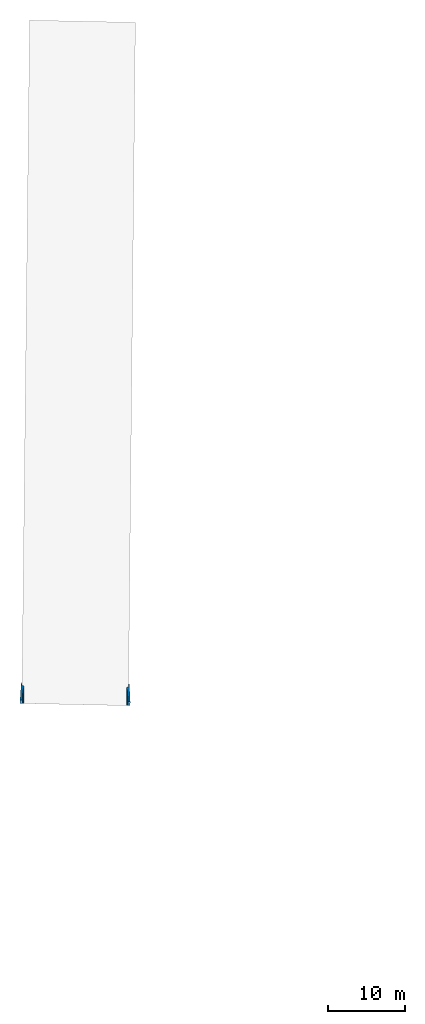
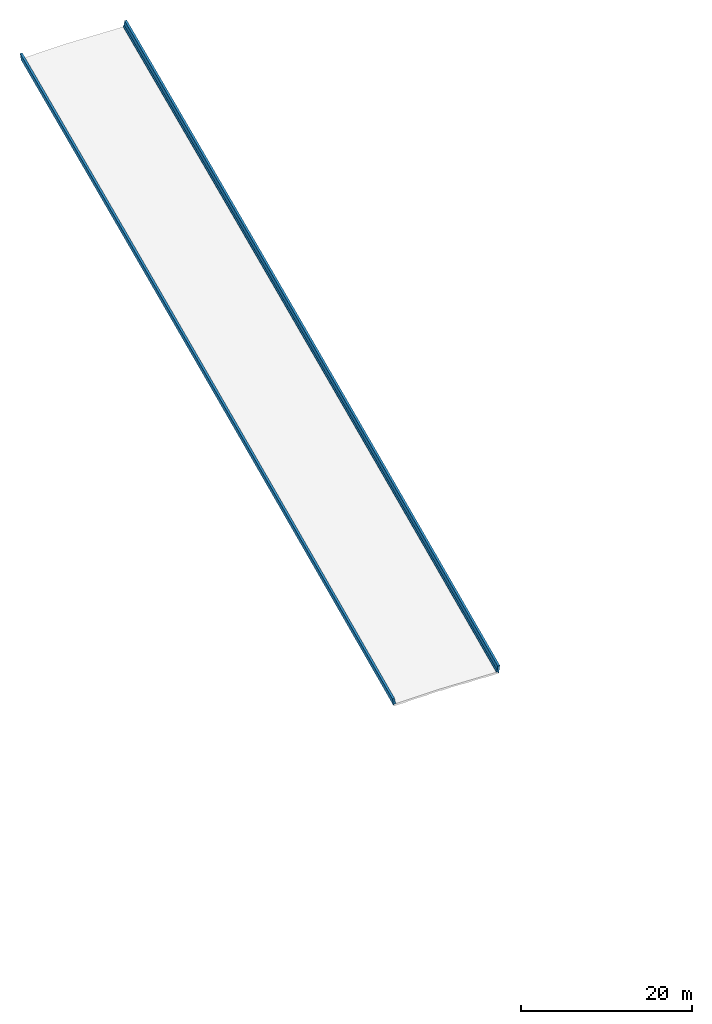
# Not in any storey, part 7 of 7: 2 walls.
"""IFC4X3_ADD2 model written with IfcOpenShell, lengths in metres."""

from ifc_helpers import new_model, entity, si_unit, direction, origin_with_axes, place, context, subcontext, project, spatial, element, save


model = new_model("IFC4X3_ADD2")

# Units and contexts
model_context = context("Model", 3, precision=1e-05, world=origin_with_axes(), true_north=direction((0.0, 1.0)))
body_context = subcontext(model_context, "Body", "Model", "MODEL_VIEW")
ifc_project = project(units=[si_unit("LENGTHUNIT", "METRE"), si_unit("PLANEANGLEUNIT", "RADIAN")], contexts=[model_context])

# Site, bridge, bridge part
placement = place(None, origin_with_axes())
site = spatial("IfcSite", under=ifc_project, at=placement, CompositionType="ELEMENT")
bridge = spatial("IfcBridge", under=site, CompositionType="COMPLEX", PredefinedType="GIRDER")
bridge_part = spatial("IfcBridgePart", under=bridge, CompositionType="PARTIAL", PredefinedType="SUPERSTRUCTURE", UsageType="LONGITUDINAL")

# Walls
gradient_curve_1 = entity("IfcGradientCurve", [entity("IfcCurveSegment", "CONTSAMEGRADIENT", entity("IfcAxis2Placement2D", entity("IfcCartesianPoint", [0.0, 225.3996]), entity("IfcDirection", [0.999837986875874, 0.018])), entity("IfcLengthMeasure", 0.0), entity("IfcLengthMeasure", 152.4), entity("IfcPolynomialCurve", entity("IfcAxis2Placement2D", entity("IfcCartesianPoint", [0.0, 0.0]), entity("IfcDirection", [1.0, 0.0])), [0.0, 1.0], [225.3996, 0.018, -0.000142388451443569])), entity("IfcCurveSegment", "CONTSAMEGRADIENT", entity("IfcAxis2Placement2D", entity("IfcCartesianPoint", [152.4, 224.83572]), entity("IfcDirection", [0.999677367954282, -0.0253999999999999])), entity("IfcLengthMeasure", 0.0), entity("IfcLengthMeasure", 19.2237360000008), entity("IfcLine", entity("IfcCartesianPoint", [0.0, 0.0]), entity("IfcVector", entity("IfcDirection", [1.0, 0.0]), 1.0))), entity("IfcCurveSegment", "DISCONTINUOUS", entity("IfcAxis2Placement2D", entity("IfcCartesianPoint", [152.4, 224.83572]), entity("IfcDirection", [0.999677367954282, -0.0253999999999999])), entity("IfcLengthMeasure", 0.0), entity("IfcLengthMeasure", 0.0), entity("IfcLine", entity("IfcCartesianPoint", [0.0, 0.0]), entity("IfcVector", entity("IfcDirection", [1.0, 0.0]), 1.0)))], False, entity("IfcCompositeCurve", [entity("IfcCurveSegment", "CONTSAMEGRADIENT", entity("IfcAxis2Placement2D", entity("IfcCartesianPoint", [80.2547679528969, 3851.83601829113]), entity("IfcDirection", [0.0208309370620953, 0.999783012488767])), entity("IfcLengthMeasure", 0.0), entity("IfcLengthMeasure", 171.623736), entity("IfcLine", entity("IfcCartesianPoint", [0.0, 0.0]), entity("IfcVector", entity("IfcDirection", [1.0, 0.0]), 1.0))), entity("IfcCurveSegment", "DISCONTINUOUS", entity("IfcAxis2Placement2D", entity("IfcCartesianPoint", [83.8298511958746, 4023.42251408378]), entity("IfcDirection", [0.0208309370620953, 0.999783012488767])), entity("IfcLengthMeasure", 0.0), entity("IfcLengthMeasure", 0.0), entity("IfcLine", entity("IfcCartesianPoint", [0.0, 0.0]), entity("IfcVector", entity("IfcDirection", [1.0, 0.0]), 1.0)))], False))
cartesian_point_1 = entity("IfcCartesianPoint", [6.021705, -0.120434099999983])
cartesian_point_2 = entity("IfcCartesianPoint", [6.018657, -0.120373139999998])
cartesian_point_3 = entity("IfcCartesianPoint", [6.015609, -0.120312179999985])
cartesian_point_4 = entity("IfcCartesianPoint", [6.012561, -0.12025122])
cartesian_point_5 = entity("IfcCartesianPoint", [6.009513, -0.120190259999987])
cartesian_point_6 = entity("IfcCartesianPoint", [6.006465, -0.120129300000002])
cartesian_point_7 = entity("IfcCartesianPoint", [6.003417, -0.120068339999989])
cartesian_point_8 = entity("IfcCartesianPoint", [6.00036899999999, -0.120007380000004])
cartesian_point_9 = entity("IfcCartesianPoint", [5.997321, -0.119946419999991])
cartesian_point_10 = entity("IfcCartesianPoint", [5.99427299999999, -0.119885459999949])
cartesian_point_11 = entity("IfcCartesianPoint", [5.991225, -0.119824499999993])
element("IfcWall", 1, at=placement, inside=bridge_part, Name="Left Railing", PredefinedType="PARAPET", context=body_context, shape_type="AdvancedSweptSolid", body=[
    entity("IfcSectionedSolidHorizontal", gradient_curve_1, [entity("IfcArbitraryClosedProfileDef", "AREA", None, entity("IfcPolyline", [cartesian_point_1, entity("IfcCartesianPoint", [5.75505832400333, -0.115101166480059]), entity("IfcCartesianPoint", [5.75658201929474, -0.0389164019095745]), entity("IfcCartesianPoint", [5.88393755073506, 0.136372043906334]), entity("IfcCartesianPoint", [5.95542425482369, 0.6938540586508]), entity("IfcCartesianPoint", [6.24746585234385, 0.688013226700377]), entity("IfcCartesianPoint", [6.10703193631894, -0.29997619517107]), entity("IfcCartesianPoint", [6.01814971098671, -0.298198550664438]), cartesian_point_1])), entity("IfcArbitraryClosedProfileDef", "AREA", None, entity("IfcPolyline", [cartesian_point_2, entity("IfcCartesianPoint", [5.75201032400334, -0.115040206480074]), entity("IfcCartesianPoint", [5.75353401929475, -0.0388554419095897]), entity("IfcCartesianPoint", [5.88088955073506, 0.136433003906319]), entity("IfcCartesianPoint", [5.95237625482369, 0.693915018650785]), entity("IfcCartesianPoint", [6.24441785234385, 0.688074186700362]), entity("IfcCartesianPoint", [6.10398393631894, -0.299915235171085]), entity("IfcCartesianPoint", [6.01510171098671, -0.298137590664453]), cartesian_point_2])), entity("IfcArbitraryClosedProfileDef", "AREA", None, entity("IfcPolyline", [cartesian_point_3, entity("IfcCartesianPoint", [5.74896232400333, -0.114979246480061]), entity("IfcCartesianPoint", [5.75048601929474, -0.0387944819095765]), entity("IfcCartesianPoint", [5.87784155073505, 0.136493963906332]), entity("IfcCartesianPoint", [5.94932825482368, 0.693975978650798]), entity("IfcCartesianPoint", [6.24136985234384, 0.688135146700375]), entity("IfcCartesianPoint", [6.10093593631893, -0.299854275171072]), entity("IfcCartesianPoint", [6.01205371098671, -0.29807663066444]), cartesian_point_3])), entity("IfcArbitraryClosedProfileDef", "AREA", None, entity("IfcPolyline", [cartesian_point_4, entity("IfcCartesianPoint", [5.74591432400333, -0.114918286480076]), entity("IfcCartesianPoint", [5.74743801929474, -0.0387335219095917]), entity("IfcCartesianPoint", [5.87479355073505, 0.136554923906317]), entity("IfcCartesianPoint", [5.94628025482369, 0.694036938650783]), entity("IfcCartesianPoint", [6.23832185234385, 0.68819610670036]), entity("IfcCartesianPoint", [6.09788793631893, -0.299793315171087]), entity("IfcCartesianPoint", [6.00900571098671, -0.298015670664455]), cartesian_point_4])), entity("IfcArbitraryClosedProfileDef", "AREA", None, entity("IfcPolyline", [cartesian_point_5, entity("IfcCartesianPoint", [5.74286632400333, -0.114857326480063]), entity("IfcCartesianPoint", [5.74439001929474, -0.0386725619095785]), entity("IfcCartesianPoint", [5.87174555073506, 0.13661588390633]), entity("IfcCartesianPoint", [5.94323225482369, 0.694097898650796]), entity("IfcCartesianPoint", [6.23527385234385, 0.688257066700373]), entity("IfcCartesianPoint", [6.09483993631894, -0.299732355171074]), entity("IfcCartesianPoint", [6.00595771098671, -0.297954710664442]), cartesian_point_5])), entity("IfcArbitraryClosedProfileDef", "AREA", None, entity("IfcPolyline", [cartesian_point_6, entity("IfcCartesianPoint", [5.73981832400333, -0.114796366480078]), entity("IfcCartesianPoint", [5.74134201929474, -0.0386116019095937]), entity("IfcCartesianPoint", [5.86869755073505, 0.136676843906315]), entity("IfcCartesianPoint", [5.94018425482368, 0.694158858650781]), entity("IfcCartesianPoint", [6.23222585234384, 0.688318026700358]), entity("IfcCartesianPoint", [6.09179193631893, -0.299671395171089]), entity("IfcCartesianPoint", [6.00290971098671, -0.297893750664457]), cartesian_point_6])), entity("IfcArbitraryClosedProfileDef", "AREA", None, entity("IfcPolyline", [cartesian_point_7, entity("IfcCartesianPoint", [5.73677032400333, -0.114735406480065]), entity("IfcCartesianPoint", [5.73829401929474, -0.0385506419095805]), entity("IfcCartesianPoint", [5.86564955073505, 0.136737803906328]), entity("IfcCartesianPoint", [5.93713625482368, 0.694219818650794]), entity("IfcCartesianPoint", [6.22917785234384, 0.688378986700371]), entity("IfcCartesianPoint", [6.08874393631893, -0.299610435171076]), entity("IfcCartesianPoint", [5.99986171098671, -0.297832790664444]), cartesian_point_7])), entity("IfcArbitraryClosedProfileDef", "AREA", None, entity("IfcPolyline", [cartesian_point_8, entity("IfcCartesianPoint", [5.73372232400332, -0.11467444648008]), entity("IfcCartesianPoint", [5.73524601929473, -0.0384896819095957]), entity("IfcCartesianPoint", [5.86260155073504, 0.136798763906313]), entity("IfcCartesianPoint", [5.93408825482367, 0.694280778650779]), entity("IfcCartesianPoint", [6.22612985234383, 0.688439946700356]), entity("IfcCartesianPoint", [6.08569593631892, -0.299549475171091]), entity("IfcCartesianPoint", [5.9968137109867, -0.297771830664459]), cartesian_point_8])), entity("IfcArbitraryClosedProfileDef", "AREA", None, entity("IfcPolyline", [cartesian_point_9, entity("IfcCartesianPoint", [5.73067432400333, -0.114613486480067]), entity("IfcCartesianPoint", [5.73219801929474, -0.0384287219095825]), entity("IfcCartesianPoint", [5.85955355073505, 0.136859723906326]), entity("IfcCartesianPoint", [5.93104025482369, 0.694341738650792]), entity("IfcCartesianPoint", [6.22308185234385, 0.688500906700369]), entity("IfcCartesianPoint", [6.08264793631893, -0.299488515171078]), entity("IfcCartesianPoint", [5.99376571098671, -0.297710870664446]), cartesian_point_9])), entity("IfcArbitraryClosedProfileDef", "AREA", None, entity("IfcPolyline", [cartesian_point_10, entity("IfcCartesianPoint", [5.72762632400332, -0.114552526480026]), entity("IfcCartesianPoint", [5.72915001929473, -0.0383677619095408]), entity("IfcCartesianPoint", [5.85650555073505, 0.136920683906368]), entity("IfcCartesianPoint", [5.92799225482368, 0.694402698650833]), entity("IfcCartesianPoint", [6.22003385234384, 0.688561866700411]), entity("IfcCartesianPoint", [6.07959993631893, -0.299427555171036]), entity("IfcCartesianPoint", [5.9907177109867, -0.297649910664404]), cartesian_point_10])), entity("IfcArbitraryClosedProfileDef", "AREA", None, entity("IfcPolyline", [cartesian_point_11, entity("IfcCartesianPoint", [5.72457832400333, -0.114491566480069]), entity("IfcCartesianPoint", [5.72610201929474, -0.0383068019095845]), entity("IfcCartesianPoint", [5.85345755073505, 0.136981643906324]), entity("IfcCartesianPoint", [5.92494425482368, 0.69446365865079]), entity("IfcCartesianPoint", [6.21698585234384, 0.688622826700367]), entity("IfcCartesianPoint", [6.07655193631893, -0.29936659517108]), entity("IfcCartesianPoint", [5.98766971098671, -0.297588950664448]), cartesian_point_11]))], [entity("IfcAxis2PlacementLinear", entity("IfcPointByDistanceExpression", entity("IfcLengthMeasure", 88.1816879999997), None, None, None, gradient_curve_1)), entity("IfcAxis2PlacementLinear", entity("IfcPointByDistanceExpression", entity("IfcLengthMeasure", 92.3537903999995), None, None, None, gradient_curve_1)), entity("IfcAxis2PlacementLinear", entity("IfcPointByDistanceExpression", entity("IfcLengthMeasure", 96.5258927999998), None, None, None, gradient_curve_1)), entity("IfcAxis2PlacementLinear", entity("IfcPointByDistanceExpression", entity("IfcLengthMeasure", 100.6979952), None, None, None, gradient_curve_1)), entity("IfcAxis2PlacementLinear", entity("IfcPointByDistanceExpression", entity("IfcLengthMeasure", 104.8700976), None, None, None, gradient_curve_1)), entity("IfcAxis2PlacementLinear", entity("IfcPointByDistanceExpression", entity("IfcLengthMeasure", 109.0422), None, None, None, gradient_curve_1)), entity("IfcAxis2PlacementLinear", entity("IfcPointByDistanceExpression", entity("IfcLengthMeasure", 113.2143024), None, None, None, gradient_curve_1)), entity("IfcAxis2PlacementLinear", entity("IfcPointByDistanceExpression", entity("IfcLengthMeasure", 117.3864048), None, None, None, gradient_curve_1)), entity("IfcAxis2PlacementLinear", entity("IfcPointByDistanceExpression", entity("IfcLengthMeasure", 121.558507199999), None, None, None, gradient_curve_1)), entity("IfcAxis2PlacementLinear", entity("IfcPointByDistanceExpression", entity("IfcLengthMeasure", 125.7306096), None, None, None, gradient_curve_1)), entity("IfcAxis2PlacementLinear", entity("IfcPointByDistanceExpression", entity("IfcLengthMeasure", 129.902712), None, None, None, gradient_curve_1))]),
])
gradient_curve_2 = entity("IfcGradientCurve", [entity("IfcCurveSegment", "CONTSAMEGRADIENT", entity("IfcAxis2Placement2D", entity("IfcCartesianPoint", [0.0, 225.3996]), entity("IfcDirection", [0.999837986875874, 0.018])), entity("IfcLengthMeasure", 0.0), entity("IfcLengthMeasure", 152.4), entity("IfcPolynomialCurve", entity("IfcAxis2Placement2D", entity("IfcCartesianPoint", [0.0, 0.0]), entity("IfcDirection", [1.0, 0.0])), [0.0, 1.0], [225.3996, 0.018, -0.000142388451443569])), entity("IfcCurveSegment", "CONTSAMEGRADIENT", entity("IfcAxis2Placement2D", entity("IfcCartesianPoint", [152.4, 224.83572]), entity("IfcDirection", [0.999677367954282, -0.0253999999999999])), entity("IfcLengthMeasure", 0.0), entity("IfcLengthMeasure", 19.2237360000008), entity("IfcLine", entity("IfcCartesianPoint", [0.0, 0.0]), entity("IfcVector", entity("IfcDirection", [1.0, 0.0]), 1.0))), entity("IfcCurveSegment", "DISCONTINUOUS", entity("IfcAxis2Placement2D", entity("IfcCartesianPoint", [152.4, 224.83572]), entity("IfcDirection", [0.999677367954282, -0.0253999999999999])), entity("IfcLengthMeasure", 0.0), entity("IfcLengthMeasure", 0.0), entity("IfcLine", entity("IfcCartesianPoint", [0.0, 0.0]), entity("IfcVector", entity("IfcDirection", [1.0, 0.0]), 1.0)))], False, entity("IfcCompositeCurve", [entity("IfcCurveSegment", "CONTSAMEGRADIENT", entity("IfcAxis2Placement2D", entity("IfcCartesianPoint", [80.2547679528969, 3851.83601829113]), entity("IfcDirection", [0.0208309370620953, 0.999783012488767])), entity("IfcLengthMeasure", 0.0), entity("IfcLengthMeasure", 171.623736), entity("IfcLine", entity("IfcCartesianPoint", [0.0, 0.0]), entity("IfcVector", entity("IfcDirection", [1.0, 0.0]), 1.0))), entity("IfcCurveSegment", "DISCONTINUOUS", entity("IfcAxis2Placement2D", entity("IfcCartesianPoint", [83.8298511958746, 4023.42251408378]), entity("IfcDirection", [0.0208309370620953, 0.999783012488767])), entity("IfcLengthMeasure", 0.0), entity("IfcLengthMeasure", 0.0), entity("IfcLine", entity("IfcCartesianPoint", [0.0, 0.0]), entity("IfcVector", entity("IfcDirection", [1.0, 0.0]), 1.0)))], False))
cartesian_point_12 = entity("IfcCartesianPoint", [-7.83869471108831, -0.334609450666505])
cartesian_point_13 = entity("IfcCartesianPoint", [-7.83170971107815, -0.334469750666301])
cartesian_point_14 = entity("IfcCartesianPoint", [-7.824724711068, -0.334330050666097])
cartesian_point_15 = entity("IfcCartesianPoint", [-7.81773971105783, -0.334190350665892])
cartesian_point_16 = entity("IfcCartesianPoint", [-7.81075471104767, -0.334050650665688])
cartesian_point_17 = entity("IfcCartesianPoint", [-7.80376971103752, -0.333910950665484])
cartesian_point_18 = entity("IfcCartesianPoint", [-7.79678471102735, -0.333771250665279])
cartesian_point_19 = entity("IfcCartesianPoint", [-7.7897997110172, -0.333631550665075])
cartesian_point_20 = entity("IfcCartesianPoint", [-7.78281471100703, -0.333491850664871])
cartesian_point_21 = entity("IfcCartesianPoint", [-7.77582971099688, -0.333352150664638])
cartesian_point_22 = entity("IfcCartesianPoint", [-7.76884471098672, -0.333212450664462])
element("IfcWall", 2, at=placement, inside=bridge_part, Name="Right Railing", PredefinedType="PARAPET", context=body_context, shape_type="AdvancedSweptSolid", body=[
    entity("IfcSectionedSolidHorizontal", gradient_curve_2, [entity("IfcArbitraryClosedProfileDef", "AREA", None, entity("IfcPolyline", [cartesian_point_12, entity("IfcCartesianPoint", [-7.92757693642053, -0.336387095173137]), entity("IfcCartesianPoint", [-8.06801085244545, 0.65160232669831]), entity("IfcCartesianPoint", [-7.77596925492529, 0.657443158648732]), entity("IfcCartesianPoint", [-7.70448255083666, 0.0999611439042667]), entity("IfcCartesianPoint", [-7.57712701939634, -0.0753273019116421]), entity("IfcCartesianPoint", [-7.57560332410493, -0.151512066482127]), entity("IfcCartesianPoint", [-7.8422500001016, -0.15684500000205]), cartesian_point_12])), entity("IfcArbitraryClosedProfileDef", "AREA", None, entity("IfcPolyline", [cartesian_point_13, entity("IfcCartesianPoint", [-7.92059193641037, -0.336247395172933]), entity("IfcCartesianPoint", [-8.06102585243528, 0.651742026698514]), entity("IfcCartesianPoint", [-7.76898425491512, 0.657582858648937]), entity("IfcCartesianPoint", [-7.69749755082649, 0.100100843904471]), entity("IfcCartesianPoint", [-7.57014201938618, -0.0751876019114377]), entity("IfcCartesianPoint", [-7.56861832409477, -0.151372366481922]), entity("IfcCartesianPoint", [-7.83526500009144, -0.156705300001846]), cartesian_point_13])), entity("IfcArbitraryClosedProfileDef", "AREA", None, entity("IfcPolyline", [cartesian_point_14, entity("IfcCartesianPoint", [-7.91360693640022, -0.336107695172728]), entity("IfcCartesianPoint", [-8.05404085242513, 0.651881726698718]), entity("IfcCartesianPoint", [-7.76199925490497, 0.657722558649141]), entity("IfcCartesianPoint", [-7.69051255081634, 0.100240543904675]), entity("IfcCartesianPoint", [-7.56315701937603, -0.0750479019112333]), entity("IfcCartesianPoint", [-7.56163332408462, -0.151232666481718]), entity("IfcCartesianPoint", [-7.82828000008128, -0.156565600001642]), cartesian_point_14])), entity("IfcArbitraryClosedProfileDef", "AREA", None, entity("IfcPolyline", [cartesian_point_15, entity("IfcCartesianPoint", [-7.90662193639006, -0.335967995172524]), entity("IfcCartesianPoint", [-8.04705585241497, 0.652021426698923]), entity("IfcCartesianPoint", [-7.75501425489481, 0.657862258649345]), entity("IfcCartesianPoint", [-7.68352755080618, 0.10038024390488]), entity("IfcCartesianPoint", [-7.55617201936586, -0.074908201911029]), entity("IfcCartesianPoint", [-7.55464832407445, -0.151092966481514]), entity("IfcCartesianPoint", [-7.82129500007112, -0.156425900001437]), cartesian_point_15])), entity("IfcArbitraryClosedProfileDef", "AREA", None, entity("IfcPolyline", [cartesian_point_16, entity("IfcCartesianPoint", [-7.89963693637989, -0.33582829517232]), entity("IfcCartesianPoint", [-8.0400708524048, 0.652161126699127]), entity("IfcCartesianPoint", [-7.74802925488464, 0.65800195864955]), entity("IfcCartesianPoint", [-7.67654255079601, 0.100519943905084]), entity("IfcCartesianPoint", [-7.5491870193557, -0.0747685019108246]), entity("IfcCartesianPoint", [-7.54766332406429, -0.150953266481309]), entity("IfcCartesianPoint", [-7.81431000006096, -0.156286200001233]), cartesian_point_16])), entity("IfcArbitraryClosedProfileDef", "AREA", None, entity("IfcPolyline", [cartesian_point_17, entity("IfcCartesianPoint", [-7.89265193636974, -0.335688595172115]), entity("IfcCartesianPoint", [-8.03308585239465, 0.652300826699332]), entity("IfcCartesianPoint", [-7.74104425487449, 0.658141658649754]), entity("IfcCartesianPoint", [-7.66955755078586, 0.100659643905288]), entity("IfcCartesianPoint", [-7.54220201934555, -0.0746288019106203]), entity("IfcCartesianPoint", [-7.54067832405414, -0.150813566481105]), entity("IfcCartesianPoint", [-7.80732500005081, -0.156146500001029]), cartesian_point_17])), entity("IfcArbitraryClosedProfileDef", "AREA", None, entity("IfcPolyline", [cartesian_point_18, entity("IfcCartesianPoint", [-7.88566693635958, -0.335548895171911]), entity("IfcCartesianPoint", [-8.02610085238449, 0.652440526699536]), entity("IfcCartesianPoint", [-7.73405925486433, 0.658281358649958]), entity("IfcCartesianPoint", [-7.6625725507757, 0.100799343905493]), entity("IfcCartesianPoint", [-7.53521701933538, -0.0744891019104159]), entity("IfcCartesianPoint", [-7.53369332404397, -0.150673866480901]), entity("IfcCartesianPoint", [-7.80034000004064, -0.156006800000824]), cartesian_point_18])), entity("IfcArbitraryClosedProfileDef", "AREA", None, entity("IfcPolyline", [cartesian_point_19, entity("IfcCartesianPoint", [-7.87868193634943, -0.335409195171707]), entity("IfcCartesianPoint", [-8.01911585237434, 0.65258022669974]), entity("IfcCartesianPoint", [-7.72707425485418, 0.658421058650163]), entity("IfcCartesianPoint", [-7.65558755076555, 0.100939043905697]), entity("IfcCartesianPoint", [-7.52823201932524, -0.0743494019102116]), entity("IfcCartesianPoint", [-7.52670832403383, -0.150534166480696]), entity("IfcCartesianPoint", [-7.79335500003049, -0.15586710000062]), cartesian_point_19])), entity("IfcArbitraryClosedProfileDef", "AREA", None, entity("IfcPolyline", [cartesian_point_20, entity("IfcCartesianPoint", [-7.87169693633926, -0.335269495171502]), entity("IfcCartesianPoint", [-8.01213085236417, 0.652719926699945]), entity("IfcCartesianPoint", [-7.72008925484401, 0.658560758650367]), entity("IfcCartesianPoint", [-7.64860255075538, 0.101078743905902]), entity("IfcCartesianPoint", [-7.52124701931506, -0.0742097019100072]), entity("IfcCartesianPoint", [-7.51972332402365, -0.150394466480492]), entity("IfcCartesianPoint", [-7.78637000002032, -0.155727400000416]), cartesian_point_20])), entity("IfcArbitraryClosedProfileDef", "AREA", None, entity("IfcPolyline", [cartesian_point_21, entity("IfcCartesianPoint", [-7.8647119363291, -0.33512979517127]), entity("IfcCartesianPoint", [-8.00514585235401, 0.652859626700177]), entity("IfcCartesianPoint", [-7.71310425483385, 0.6587004586506]), entity("IfcCartesianPoint", [-7.64161755074522, 0.101218443906134]), entity("IfcCartesianPoint", [-7.51426201930491, -0.0740700019097744]), entity("IfcCartesianPoint", [-7.5127383240135, -0.150254766480259]), entity("IfcCartesianPoint", [-7.77938500001017, -0.155587700000183]), cartesian_point_21])), entity("IfcArbitraryClosedProfileDef", "AREA", None, entity("IfcPolyline", [cartesian_point_22, entity("IfcCartesianPoint", [-7.85772693631894, -0.334990095171094]), entity("IfcCartesianPoint", [-7.99816085234385, 0.652999326700353]), entity("IfcCartesianPoint", [-7.70611925482369, 0.658840158650776]), entity("IfcCartesianPoint", [-7.63463255073506, 0.10135814390631]), entity("IfcCartesianPoint", [-7.50727701929475, -0.0739303019095985]), entity("IfcCartesianPoint", [-7.50575332400334, -0.150115066480083]), entity("IfcCartesianPoint", [-7.77240000000001, -0.155448000000007]), cartesian_point_22]))], [entity("IfcAxis2PlacementLinear", entity("IfcPointByDistanceExpression", entity("IfcLengthMeasure", 88.1816879999997), None, None, None, gradient_curve_2)), entity("IfcAxis2PlacementLinear", entity("IfcPointByDistanceExpression", entity("IfcLengthMeasure", 92.3537903999995), None, None, None, gradient_curve_2)), entity("IfcAxis2PlacementLinear", entity("IfcPointByDistanceExpression", entity("IfcLengthMeasure", 96.5258927999998), None, None, None, gradient_curve_2)), entity("IfcAxis2PlacementLinear", entity("IfcPointByDistanceExpression", entity("IfcLengthMeasure", 100.6979952), None, None, None, gradient_curve_2)), entity("IfcAxis2PlacementLinear", entity("IfcPointByDistanceExpression", entity("IfcLengthMeasure", 104.8700976), None, None, None, gradient_curve_2)), entity("IfcAxis2PlacementLinear", entity("IfcPointByDistanceExpression", entity("IfcLengthMeasure", 109.0422), None, None, None, gradient_curve_2)), entity("IfcAxis2PlacementLinear", entity("IfcPointByDistanceExpression", entity("IfcLengthMeasure", 113.2143024), None, None, None, gradient_curve_2)), entity("IfcAxis2PlacementLinear", entity("IfcPointByDistanceExpression", entity("IfcLengthMeasure", 117.3864048), None, None, None, gradient_curve_2)), entity("IfcAxis2PlacementLinear", entity("IfcPointByDistanceExpression", entity("IfcLengthMeasure", 121.558507199999), None, None, None, gradient_curve_2)), entity("IfcAxis2PlacementLinear", entity("IfcPointByDistanceExpression", entity("IfcLengthMeasure", 125.7306096), None, None, None, gradient_curve_2)), entity("IfcAxis2PlacementLinear", entity("IfcPointByDistanceExpression", entity("IfcLengthMeasure", 129.902712), None, None, None, gradient_curve_2))]),
])

save(model, "model.ifc")
